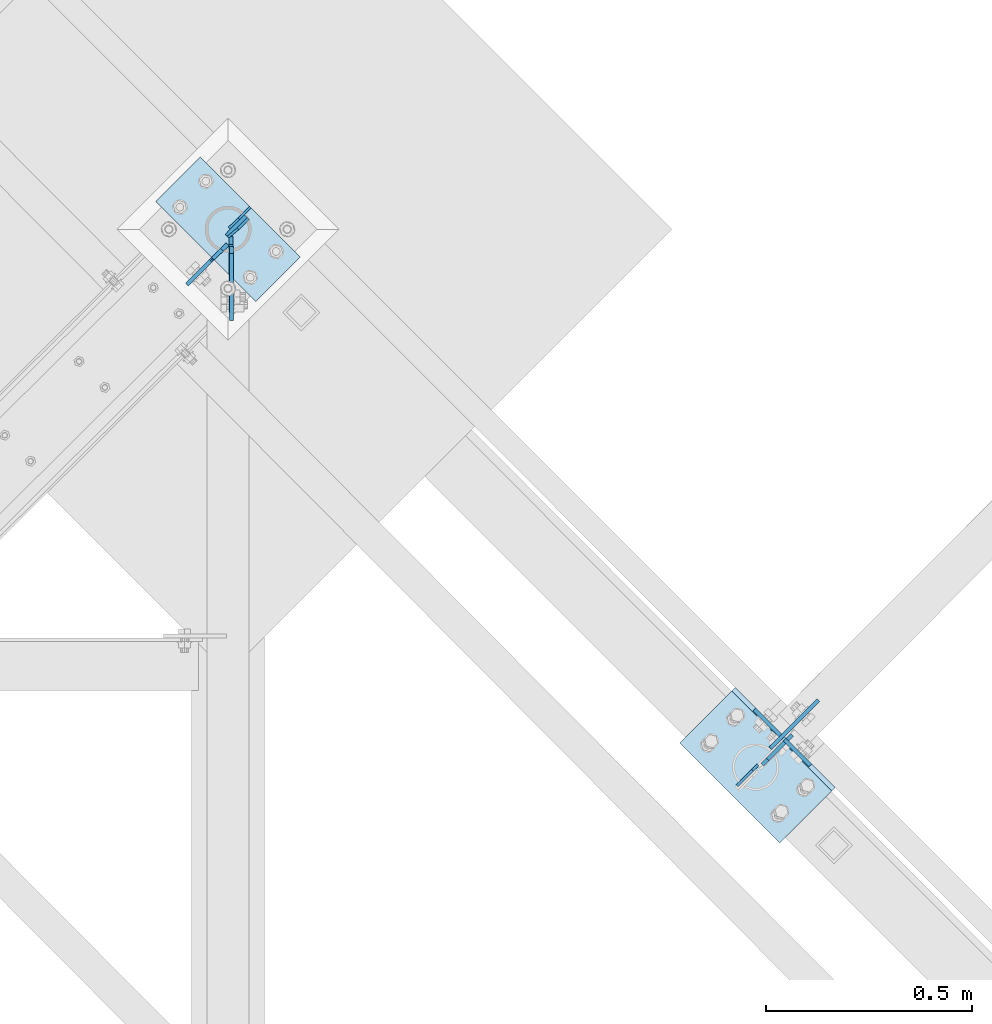
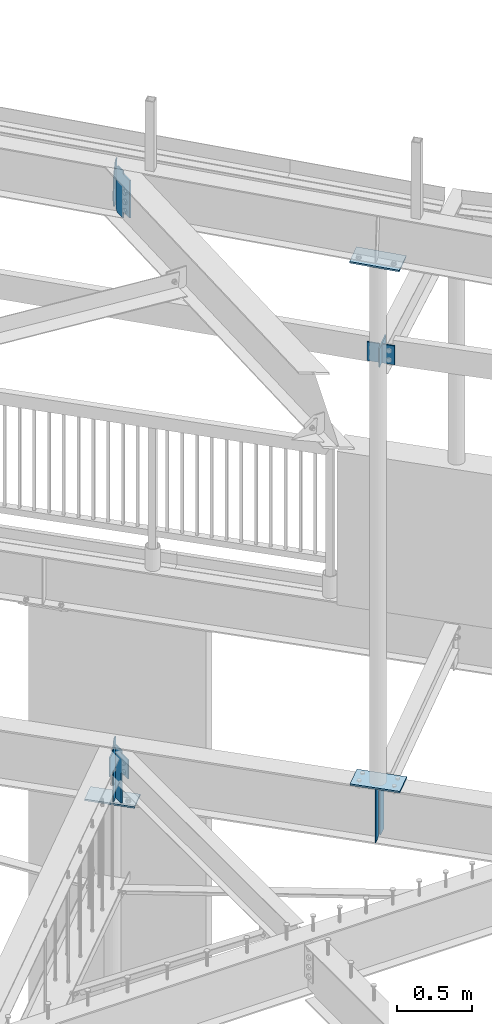
# One storey, part 924 of 975: 13 plates.
"""IFC2X3 building model written with IfcOpenShell, lengths in millimetres."""

from ifc_helpers import new_model, si_unit, frame, origin_with_axes, place, context, subcontext, project, spatial, faceted_brep, material, type_object, element, save


model = new_model("IFC2X3")

# Units and contexts
model_context = context("Model", 3, precision=1e-05, world=origin_with_axes())
body_context = subcontext(model_context, "Body", "Model", "MODEL_VIEW")
ifc_project = project(units=[si_unit("LENGTHUNIT", "METRE", prefix="MILLI"), si_unit("AREAUNIT", "SQUARE_METRE"), si_unit("VOLUMEUNIT", "CUBIC_METRE"), si_unit("MASSUNIT", "GRAM", prefix="KILO"), si_unit("TIMEUNIT", "SECOND"), si_unit("PLANEANGLEUNIT", "RADIAN"), si_unit("SOLIDANGLEUNIT", "STERADIAN"), si_unit("THERMODYNAMICTEMPERATUREUNIT", "DEGREE_CELSIUS"), si_unit("LUMINOUSINTENSITYUNIT", "LUMEN")], contexts=[model_context])

# Site, building, storey
site_placement = place(None, origin_with_axes())
site = spatial("IfcSite", under=ifc_project, at=site_placement, CompositionType="ELEMENT")
building_placement = place(site_placement, origin_with_axes())
building = spatial("IfcBuilding", under=site, at=building_placement, Name="Undefined", CompositionType="ELEMENT")
storey_placement = place(building_placement, origin_with_axes())
storey = spatial("IfcBuildingStorey", under=building, at=storey_placement, Name="Undefined", CompositionType="ELEMENT", Elevation=0.0)

# Plates
ifc_material = material(Name="STEEL/A36")
plate_type_1 = type_object("IfcPlateType", PredefinedType="NOTDEFINED")
plate_1_placement = place(storey_placement, frame((31129.2563556926, 14664.8892634223, 3495.67500000005), z_axis=(0.0, 0.0, 1.0), x_axis=(0.706311124041062, 0.707901544041155, 0.0)))
element("IfcPlate", 1, at=plate_1_placement, inside=storey, type_object=plate_type_1, material=ifc_material, Name="PLATE", context=body_context, shape_type="Brep", body=[
    faceted_brep([(0.0, -4.76250000000073, 17.4624996185303), (0.0, -4.76250000000073, 411.16250038147), (0.0, 4.76250000000073, 411.16250038147), (0.0, 4.76250000000073, 17.4624996185303), (17.4624996185303, -4.76250000000073, 428.625), (17.4624996185303, 4.76250000000073, 428.625), (101.600006103516, -4.76250000000073, 428.625), (101.600006103516, 4.76250000000073, 428.625), (101.600006103516, -4.76250000000073, 0.0), (101.600006103516, 4.76250000000073, 0.0), (17.4624996185303, -4.76250000000073, 0.0), (17.4624996185303, 4.76250000000073, 0.0)], [[[0, 1, 2, 3]], [[1, 4, 5, 2]], [[4, 6, 7, 5]], [[6, 8, 9, 7]], [[8, 10, 11, 9]], [[10, 0, 3, 11]], [[5, 7, 9, 11, 3, 2]], [[10, 8, 6, 4, 1, 0]]]),
])
plate_type_2 = type_object("IfcPlateType", PredefinedType="NOTDEFINED")
plate_2_placement = place(storey_placement, frame((29841.0312500307, 15922.0417556649, 8265.52768741902), z_axis=(0.0, -0.707106781186557, 0.707106781186538), x_axis=(0.0, -0.707106781186538, -0.707106781186557)))
element("IfcPlate", 2, at=plate_2_placement, inside=storey, type_object=plate_type_2, material=ifc_material, Name="PLATE", context=body_context, shape_type="Brep", body=[
    faceted_brep([(0.0, -4.76250000000073, 0.0), (-244.547378540154, -4.76250000000073, 244.547378540008), (-244.547378540154, 4.76250000000073, 244.547378540008), (0.0, 4.76250000000073, 0.0), (-244.547378540159, -4.76250000000073, 269.24307250974), (-244.547378540159, 4.76250000000073, 269.24307250974), (-192.192565918111, -4.76250000000073, 319.422058105457), (-192.192565918111, 4.76250000000073, 319.422058105457), (-186.749020029085, -4.76250000000073, 313.742479410423), (-186.749020029085, 4.76250000000073, 313.742479410423), (-182.633377976515, -4.76250000000073, 310.878755551827), (-182.633377976515, 4.76250000000073, 310.878755551827), (-177.730134072306, -4.76250000000073, 309.831080478625), (-177.730134072306, 4.76250000000073, 309.831080478625), (-172.803531173529, -4.76250000000073, 310.762749798147), (-172.803531173529, 4.76250000000073, 310.762749798147), (-168.621452980969, -4.76250000000073, 313.528549110185), (-168.621452980969, 4.76250000000073, 313.528549110185), (-114.412872314599, -4.76250000000073, 367.479187011741), (-114.412872314599, 4.76250000000073, 367.479187011741), (101.113273620569, -4.76250000000073, 151.953033447326), (101.113273620569, 4.76250000000073, 151.953033447326), (47.7230857217583, -4.76250000000073, 98.7801508490729), (47.7230857217583, 4.76250000000073, 98.7801508490729), (44.9852267751703, -4.76250000000073, 94.7217485272404), (44.9852267751703, 4.76250000000073, 94.7217485272404), (43.9858691865302, -4.76250000000073, 89.9292767821671), (43.9858691865302, 4.76250000000073, 89.9292767821671), (44.8735101062193, -4.76250000000073, 85.1148614890126), (44.8735101062193, 4.76250000000073, 85.1148614890126), (47.5162526550484, -4.76250000000073, 80.9938891719621), (47.5162526550484, 4.76250000000073, 80.9938891719621), (77.0505142211878, -4.76250000000073, 50.1789855957386), (77.0505142211878, 4.76250000000073, 50.1789855957386), (24.6957035064406, -4.76250000000073, -6.3664629124105e-11), (24.6957035064406, 4.76250000000073, -6.3664629124105e-11)], [[[0, 1, 2, 3]], [[1, 4, 5, 2]], [[4, 6, 7, 5]], [[6, 8, 9, 7]], [[8, 10, 11, 9]], [[10, 12, 13, 11]], [[12, 14, 15, 13]], [[14, 16, 17, 15]], [[16, 18, 19, 17]], [[18, 20, 21, 19]], [[20, 22, 23, 21]], [[22, 24, 25, 23]], [[24, 26, 27, 25]], [[26, 28, 29, 27]], [[28, 30, 31, 29]], [[30, 32, 33, 31]], [[32, 34, 35, 33]], [[34, 0, 3, 35]], [[5, 7, 9, 11, 13, 15, 17, 19, 21, 23, 25, 27, 29, 31, 33, 35, 3, 2]], [[34, 32, 30, 28, 26, 24, 22, 20, 18, 16, 14, 12, 10, 8, 6, 4, 1, 0]]]),
])
plate_type_3 = type_object("IfcPlateType", PredefinedType="NOTDEFINED")
plate_3_placement = place(storey_placement, frame((31148.3760351734, 14704.3124126378, 7416.59196172646), z_axis=(0.706041106860138, 0.708170851859713, 0.0), x_axis=(0.0, 0.0, -1.0)))
element("IfcPlate", 3, at=plate_3_placement, inside=storey, type_object=plate_type_3, material=ifc_material, Name="PLATE", context=body_context, shape_type="Brep", body=[
    faceted_brep([(0.0, -4.76250000000073, 0.0), (-2.81943357549608e-11, -4.76249999991887, 165.095245361295), (-2.81943357549608e-11, 4.76250000008076, 165.095245361288), (0.0, 4.76250000000073, 0.0), (152.399993896484, -4.76249999991887, 165.095245361295), (152.399993896484, 4.76250000008076, 165.095245361288), (152.399993896484, -4.76250000000073, 0.0), (152.399993896484, 4.76250000000073, 0.0)], [[[0, 1, 2, 3]], [[1, 4, 5, 2]], [[4, 6, 7, 5]], [[6, 0, 3, 7]], [[5, 7, 3, 2]], [[6, 4, 1, 0]]]),
])
plate_type_4 = type_object("IfcPlateType", PredefinedType="NOTDEFINED")
plate_4_placement = place(storey_placement, frame((29834.088272888, 15942.7332916927, 8629.99146215711), z_axis=(-0.0212034286822236, 0.0212110253315295, -0.999550152326787), x_axis=(0.707233416345083, 0.706980123344965, 0.0)))
element("IfcPlate", 4, at=plate_4_placement, inside=storey, type_object=plate_type_4, material=ifc_material, Name="PLATE", context=body_context, shape_type="Brep", body=[
    faceted_brep([(2.81943357549608e-10, -3.17500000006476, 92.0749969482258), (0.0, -3.17499999999927, 288.924987792969), (0.0, 3.17499999999927, 288.924987792969), (2.67391442321241e-10, 3.17499999993743, 92.0749969482295), (31.7500000011059, -3.17500000022483, 380.999999999935), (31.7500000010932, 3.17499999978099, 380.999999999938), (66.6750030521289, -3.17500000019572, 380.999999999934), (66.6750030521143, 3.17499999981374, 380.999999999937), (66.6750030516614, -3.17499999994834, 7.09405867382884e-11), (66.6750030516505, 3.17500000005384, 7.36690708436072e-11), (31.75000000004, -3.17500000000246, 0.0), (31.7500000000473, 3.17499999999791, 0.0)], [[[0, 1, 2, 3]], [[1, 4, 5, 2]], [[4, 6, 7, 5]], [[6, 8, 9, 7]], [[8, 10, 11, 9]], [[10, 0, 3, 11]], [[5, 7, 9, 11, 3, 2]], [[10, 8, 6, 4, 1, 0]]]),
])
plate_type_5 = type_object("IfcPlateType", PredefinedType="NOTDEFINED")
plate_5_placement = place(storey_placement, frame((29886.3410058915, 16017.6215910458, 3495.675), z_axis=(0.0, 0.0, 1.0), x_axis=(-0.709199630836852, -0.705007718837796, 0.0)))
element("IfcPlate", 5, at=plate_5_placement, inside=storey, type_object=plate_type_5, material=ifc_material, Name="PLATE", context=body_context, shape_type="Brep", body=[
    faceted_brep([(0.0, -3.17499999999927, 0.0), (0.0, -3.17499999999927, 428.625), (0.0, 3.17499999999927, 428.625), (0.0, 3.17499999999927, 0.0), (38.8937454223196, -3.17499999997199, 428.625), (38.893745422316, 3.17500000004111, 428.625), (72.2312469481658, -3.1749999999447, 344.487503051758), (72.2312469481622, 3.17500000006476, 344.487503051758), (72.2312469481658, -3.1749999999447, 84.1374969482422), (72.2312469481622, 3.17500000006476, 84.1374969482422), (38.8937454223196, -3.17499999997199, 0.0), (38.893745422316, 3.17500000004111, 0.0)], [[[0, 1, 2, 3]], [[1, 4, 5, 2]], [[4, 6, 7, 5]], [[6, 8, 9, 7]], [[8, 10, 11, 9]], [[10, 0, 3, 11]], [[5, 7, 9, 11, 3, 2]], [[10, 8, 6, 4, 1, 0]]]),
])
plate_6_placement = place(storey_placement, frame((31067.384739863, 14613.3878489142, 3924.3), z_axis=(0.0, 0.0, -1.0), x_axis=(0.709199573009271, 0.70500777700921, 0.0)))
element("IfcPlate", 6, at=plate_6_placement, inside=storey, type_object=plate_type_5, material=ifc_material, Name="PLATE", context=body_context, shape_type="Brep", body=[
    faceted_brep([(0.0, -3.17499999999927, 0.0), (0.0, -3.17499999999927, 428.625), (0.0, 3.17499999999927, 428.625), (0.0, 3.17499999999927, 0.0), (53.1812477111816, -3.17499999999927, 428.625), (53.1812477111816, 3.17499999999927, 428.625), (72.2312469482422, -3.17499999999927, 409.575000762939), (72.2312469482422, 3.17499999999927, 409.575000762939), (72.2312469482422, -3.17499999999927, 19.0499992370605), (72.2312469482422, 3.17499999999927, 19.0499992370605), (53.1812477111816, -3.17499999999927, 0.0), (53.1812477111816, 3.17499999999927, 0.0)], [[[0, 1, 2, 3]], [[1, 4, 5, 2]], [[4, 6, 7, 5]], [[6, 8, 9, 7]], [[8, 10, 11, 9]], [[10, 0, 3, 11]], [[5, 7, 9, 11, 3, 2]], [[10, 8, 6, 4, 1, 0]]]),
])
plate_type_6 = type_object("IfcPlateType", PredefinedType="NOTDEFINED")
for number, where, z_axis, x_axis, name in (
    (7, (31183.140544714, 14725.6797047691, 7430.13211808152), (0.706980057333141, -0.70723348233326, 0.0), (0.0, 0.0, -1.0), "PLATE"),
    (8, (31173.0282043708, 14735.7956680779, 7430.618100764), (-0.706980057333141, 0.70723348233326, 0.0), (0.0, 0.0, -1.0), "PLATE"),
):
    element("IfcPlate", number, at=place(storey_placement, frame(where, z_axis=z_axis, x_axis=x_axis)), inside=storey, type_object=plate_type_6, material=ifc_material, Name=name, context=body_context, shape_type="Brep", body=[
        faceted_brep([(0.0, -4.76250000000073, 0.0), (0.0, -4.76249999999982, 88.9000015258789), (0.0, 4.76249999999982, 88.9000015258789), (0.0, 4.76250000000073, 0.0), (152.399993896484, -4.76249999999982, 88.9000015258789), (152.399993896484, 4.76249999999982, 88.9000015258789), (152.399993896484, -4.76250000000073, 0.0), (152.399993896484, 4.76250000000073, 0.0)], [[[0, 1, 2, 3]], [[1, 4, 5, 2]], [[4, 6, 7, 5]], [[6, 0, 3, 7]], [[5, 7, 3, 2]], [[6, 4, 1, 0]]]),
    ])
plate_type_7 = type_object("IfcPlateType", PredefinedType="NOTDEFINED")
plate_7_placement = place(storey_placement, frame((29839.4452500754, 15853.4196684814, 3924.3), z_axis=(0.0, 0.0, -1.0), x_axis=(0.0, 1.0, 0.0)))
element("IfcPlate", 9, at=plate_7_placement, inside=storey, type_object=plate_type_7, material=ifc_material, Name="PLATE", context=body_context, shape_type="Brep", body=[
    faceted_brep([(0.0, -4.76250000000073, 0.0), (-3.15667421091348e-08, -4.76250000000027, 12.6999998092651), (-3.15558281727135e-08, 4.76249999999936, 12.6999998092651), (0.0, 4.76250000000073, 0.0), (-0.966729922589366, -4.76250000000073, 17.5600793273115), (-0.966729922589366, 4.76250000000073, 17.5600793273115), (-3.71974382306689, -4.76250000000073, 21.6802557954647), (-3.71974382306689, 4.76250000000073, 21.6802557954647), (-7.83992029122055, -4.76250000000073, 24.4332696959427), (-7.83992029122055, 4.76250000000073, 24.4332696959427), (-12.6999998092651, -4.76250000000073, 25.3999996185303), (-12.6999998092651, 4.76250000000073, 25.3999996185303), (-91.8175735473633, -4.76250000000073, 25.3999996185303), (-91.8175735473633, 4.76250000000073, 25.3999996185303), (-91.8175735473633, -4.76250000000073, 177.800003051758), (-91.8175735473633, 4.76250000000073, 177.800003051758), (-12.699999809267, -4.76250000000073, 177.800003051758), (-12.699999809267, 4.76250000000073, 177.800003051758), (-7.83992029122055, -4.76250000000073, 178.766732974346), (-7.83992029122055, 4.76250000000073, 178.766732974346), (-3.71974382306689, -4.76250000000073, 181.519746874824), (-3.71974382306689, 4.76250000000073, 181.519746874824), (-0.966729922589366, -4.76250000000073, 185.639923342977), (-0.966729922589366, 4.76250000000073, 185.639923342977), (-1.81898940354586e-12, -4.76250000000073, 190.500002861023), (-1.81898940354586e-12, 4.76250000000073, 190.500002861023), (0.0, -4.76250000000073, 428.625), (0.0, 4.76250000000073, 428.625), (73.8229103088379, -4.76250000000073, 428.625), (73.8229103088379, 4.76250000000073, 428.625), (92.8729095458984, -4.76250000000073, 409.575000762939), (92.8729095458984, 4.76250000000073, 409.575000762939), (92.8729095458984, -4.76250000000073, 19.0499992370605), (92.8729095458984, 4.76250000000073, 19.0499992370605), (73.8229103088379, -4.76250000000073, 0.0), (73.8229103088379, 4.76250000000073, 0.0)], [[[0, 1, 2, 3]], [[1, 4, 5, 2]], [[4, 6, 7, 5]], [[6, 8, 9, 7]], [[8, 10, 11, 9]], [[10, 12, 13, 11]], [[12, 14, 15, 13]], [[14, 16, 17, 15]], [[16, 18, 19, 17]], [[18, 20, 21, 19]], [[20, 22, 23, 21]], [[22, 24, 25, 23]], [[24, 26, 27, 25]], [[26, 28, 29, 27]], [[28, 30, 31, 29]], [[30, 32, 33, 31]], [[32, 34, 35, 33]], [[34, 0, 3, 35]], [[5, 7, 9, 11, 13, 15, 17, 19, 21, 23, 25, 27, 29, 31, 33, 35, 3, 2]], [[34, 32, 30, 28, 26, 24, 22, 20, 18, 16, 14, 12, 10, 8, 6, 4, 1, 0]]]),
])
plate_type_8 = type_object("IfcPlateType", PredefinedType="NOTDEFINED")
plate_8_placement = place(storey_placement, frame((29795.7903950078, 15892.5427646856, 3924.3), z_axis=(0.0, 0.0, -1.0), x_axis=(0.709199573009271, 0.70500777700921, 0.0)))
element("IfcPlate", 10, at=plate_8_placement, inside=storey, type_object=plate_type_8, material=ifc_material, Name="PLATE", context=body_context, shape_type="Brep", body=[
    faceted_brep([(0.0, -4.76250000000073, 0.0), (-0.966729922583909, -4.76250000000618, 4.8600795180455), (-0.966729922576633, 4.762500000008, 4.8600795180455), (0.0, 4.76250000000073, 0.0), (-3.71974382306144, -4.76250000000437, 8.98025598619915), (-3.71974382304688, 4.76250000000982, 8.98025598619915), (-7.83992029120782, -4.76250000000437, 11.7332698866771), (-7.83992029120054, 4.76250000001346, 11.7332698866771), (-12.6999998092469, -4.76249999999891, 12.6999998092651), (-12.6999998092433, 4.7625000000171, 12.6999998092651), (-88.9000015257843, -4.76249999993524, 12.6999998092651), (-88.900001525777, 4.76250000008076, 12.6999998092651), (-88.9000015257843, -4.76249999993524, 165.100006103516), (-88.900001525777, 4.76250000008076, 165.100006103516), (-12.6999998092542, -4.76250000000073, 165.100006103516), (-12.6999998092469, 4.76250000001892, 165.100006103516), (-7.83992029121509, -4.76250000000073, 166.066736026104), (-7.83992029120054, 4.76250000001346, 166.066736026104), (-3.71974382306144, -4.76250000000437, 168.819749926582), (-3.71974382305416, 4.76250000000982, 168.819749926582), (-0.966729922587547, -4.76250000000982, 172.939926394735), (-0.966729922580271, 4.762500000008, 172.939926394735), (-3.63797880709171e-12, -4.76250000000618, 177.800005912781), (7.27595761418343e-12, 4.76250000000618, 177.800005912781), (0.0, -4.76250000000073, 428.625), (0.0, 4.76250000000073, 428.625), (30.9562492370278, -4.76250000003529, 428.625), (30.9562492370424, 4.76249999998072, 428.625), (50.0062484740738, -4.76250000004802, 409.575000762939), (50.0062484740811, 4.76249999996253, 409.575000762939), (50.0062484740738, -4.76250000004802, 19.0499992370605), (50.0062484740811, 4.76249999996253, 19.0499992370605), (30.9562492370278, -4.76250000003529, 0.0), (30.9562492370424, 4.76249999998072, 0.0)], [[[0, 1, 2, 3]], [[1, 4, 5, 2]], [[4, 6, 7, 5]], [[6, 8, 9, 7]], [[8, 10, 11, 9]], [[10, 12, 13, 11]], [[12, 14, 15, 13]], [[14, 16, 17, 15]], [[16, 18, 19, 17]], [[18, 20, 21, 19]], [[20, 22, 23, 21]], [[22, 24, 25, 23]], [[24, 26, 27, 25]], [[26, 28, 29, 27]], [[28, 30, 31, 29]], [[30, 32, 33, 31]], [[32, 0, 3, 33]], [[5, 7, 9, 11, 13, 15, 17, 19, 21, 23, 25, 27, 29, 31, 33, 3, 2]], [[32, 30, 28, 26, 24, 22, 20, 18, 16, 14, 12, 10, 8, 6, 4, 1, 0]]]),
])
plate_type_9 = type_object("IfcPlateType", PredefinedType="NOTDEFINED")
for number, where, z_axis, x_axis, name in (
    (11, (31296.9754966286, 14600.6200511938, 8173.42525507106), (-0.706788690770668, 0.706788690944904, 0.0299915479939673), (-0.707106895176348, -0.707106667176346, -5.36900000063523e-06), "PLATE"),
    (12, (31063.6780057098, 14851.8780061278, 3943.34999999999), (0.707106781186513, -0.707106781186582, 3.1377567211166e-14), (-0.707106781186548, -0.707106781186548, 0.0), "PLATE"),
):
    element("IfcPlate", number, at=place(storey_placement, frame(where, z_axis=z_axis, x_axis=x_axis)), inside=storey, type_object=plate_type_9, material=ifc_material, Name=name, context=body_context, shape_type="Brep", body=[
        faceted_brep([(0.0, -6.34999999998763, -3.63797880709171e-12), (-4.32919478043914e-10, -6.34999999999991, 342.899993895661), (-4.32919478043914e-10, 6.34999999999991, 342.899993895661), (0.0, 6.34999999999491, 5.45696821063757e-12), (177.800003051329, -6.34999999999991, 342.899993895658), (177.800003051329, 6.34999999999991, 342.899993895658), (177.800003051329, -6.34999999999991, -2.22826201934367e-10), (177.800003051329, 6.34999999999991, -2.22826201934367e-10)], [[[0, 1, 2, 3]], [[1, 4, 5, 2]], [[4, 6, 7, 5]], [[6, 0, 3, 7]], [[5, 7, 3, 2]], [[6, 4, 1, 0]]]),
    ])
plate_type_10 = type_object("IfcPlateType", PredefinedType="NOTDEFINED")
plate_9_placement = place(storey_placement, frame((30007.414994371, 15896.5480791015, 3476.62499999999), z_axis=(-0.707106781186601, 0.707106781186494, 2.36468622460961e-14), x_axis=(-0.707106781186548, -0.707106781186548, 0.0)))
element("IfcPlate", 13, at=plate_9_placement, inside=storey, type_object=plate_type_10, material=ifc_material, Name="PLATE", context=body_context, shape_type="Brep", body=[
    faceted_brep([(0.0, -6.34999999998763, -3.63797880709171e-12), (-4.32919478043914e-10, -6.34999999999991, 342.899993895661), (-4.32919478043914e-10, 6.34999999999991, 342.899993895661), (0.0, 6.34999999999491, 5.45696821063757e-12), (152.399993896484, -6.34999999995307, 342.899993896505), (152.399993896484, 6.35000000004766, 342.899993896504), (152.399993896484, -6.34999999999854, 9.09494701772928e-13), (152.399993896484, 6.35000000000127, 0.0)], [[[0, 1, 2, 3]], [[1, 4, 5, 2]], [[4, 6, 7, 5]], [[6, 0, 3, 7]], [[5, 7, 3, 2]], [[6, 4, 1, 0]]]),
])

save(model, "model.ifc")
